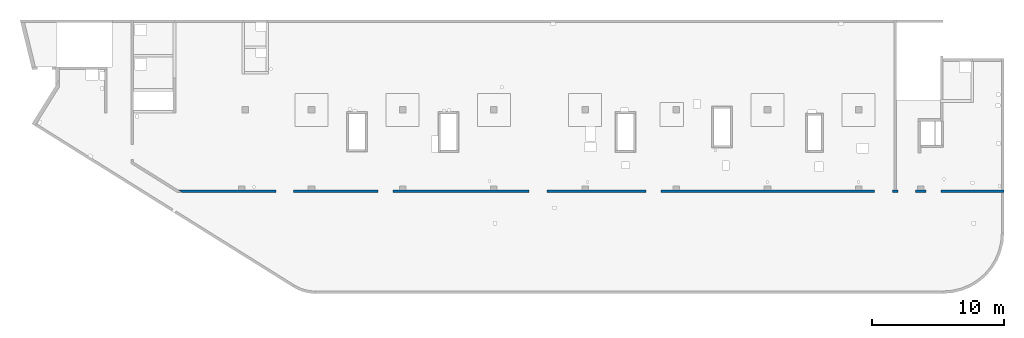
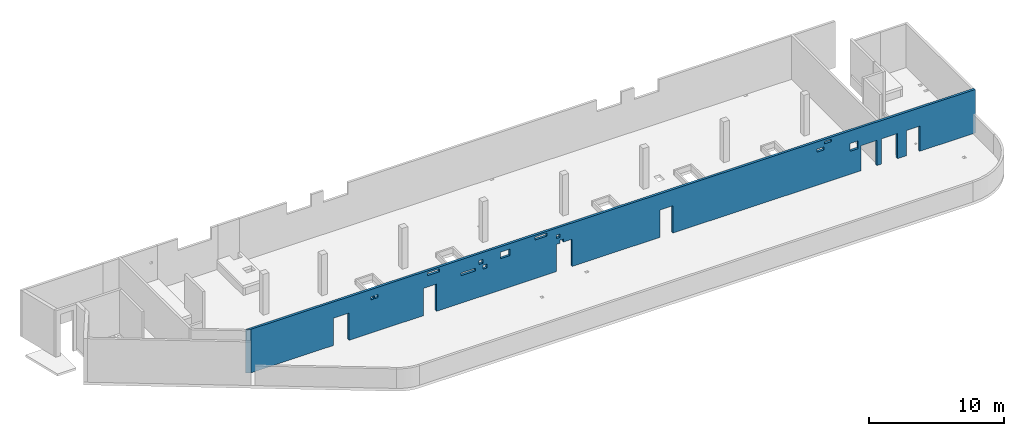
# One storey, part 5 of 6: 1 wall, 20 openings.
"""IFC4 building model written with IfcOpenShell, lengths in millimetres."""

from ifc_helpers import new_model, entity, si_unit, converted_unit, derived_unit, direction, frame, origin, place, context, subcontext, project, spatial, indexed_curve, outline, extrude, polygons, material, type_object, element, save


model = new_model("IFC4")

# Units and contexts
model_context = context("Model", 3, precision=0.01, world=origin(), true_north=direction((6.12303176911189e-17, 1.0)))
plan_context = context("Plan", 3, precision=0.01, world=origin(), true_north=direction((6.12303176911189e-17, 1.0)))
body_context = subcontext(model_context, "Body", "Model", "MODEL_VIEW")
ifc_project = project(units=[si_unit("LENGTHUNIT", "METRE", prefix="MILLI"), si_unit("AREAUNIT", "SQUARE_METRE"), si_unit("VOLUMEUNIT", "CUBIC_METRE"), converted_unit("PLANEANGLEUNIT", "DEGREE", entity("IfcRatioMeasure", 0.0174532925199433), si_unit("PLANEANGLEUNIT", "RADIAN"), dimensions=[0, 0, 0, 0, 0, 0, 0]), si_unit("MASSUNIT", "GRAM", prefix="KILO"), derived_unit("MASSDENSITYUNIT", [(si_unit("MASSUNIT", "GRAM", prefix="KILO"), 1), (si_unit("LENGTHUNIT", "METRE"), -3)]), derived_unit("MOMENTOFINERTIAUNIT", [(si_unit("LENGTHUNIT", "METRE"), 4)]), si_unit("TIMEUNIT", "SECOND"), si_unit("FREQUENCYUNIT", "HERTZ"), si_unit("THERMODYNAMICTEMPERATUREUNIT", "DEGREE_CELSIUS"), derived_unit("THERMALTRANSMITTANCEUNIT", [(si_unit("MASSUNIT", "GRAM", prefix="KILO"), 1), (si_unit("THERMODYNAMICTEMPERATUREUNIT", "KELVIN"), -1), (si_unit("TIMEUNIT", "SECOND"), -3)]), derived_unit("VOLUMETRICFLOWRATEUNIT", [(si_unit("LENGTHUNIT", "METRE"), 3), (si_unit("TIMEUNIT", "SECOND"), -1)]), derived_unit("MASSFLOWRATEUNIT", [(si_unit("MASSUNIT", "GRAM", prefix="KILO"), 1), (si_unit("TIMEUNIT", "SECOND"), -1)]), derived_unit("ROTATIONALFREQUENCYUNIT", [(si_unit("TIMEUNIT", "SECOND"), -1)]), si_unit("ELECTRICCURRENTUNIT", "AMPERE"), si_unit("ELECTRICVOLTAGEUNIT", "VOLT"), si_unit("POWERUNIT", "WATT"), si_unit("FORCEUNIT", "NEWTON", prefix="KILO"), si_unit("ILLUMINANCEUNIT", "LUX"), si_unit("LUMINOUSFLUXUNIT", "LUMEN"), si_unit("LUMINOUSINTENSITYUNIT", "CANDELA"), derived_unit("USERDEFINED", [(si_unit("MASSUNIT", "GRAM", prefix="KILO"), -1), (si_unit("LENGTHUNIT", "METRE"), -2), (si_unit("TIMEUNIT", "SECOND"), 3), (si_unit("LUMINOUSFLUXUNIT", "LUMEN"), 1)]), derived_unit("LINEARVELOCITYUNIT", [(si_unit("LENGTHUNIT", "METRE"), 1), (si_unit("TIMEUNIT", "SECOND"), -1)]), si_unit("PRESSUREUNIT", "PASCAL"), derived_unit("USERDEFINED", [(si_unit("LENGTHUNIT", "METRE"), -2), (si_unit("MASSUNIT", "GRAM", prefix="KILO"), 1), (si_unit("TIMEUNIT", "SECOND"), -2)]), derived_unit("LINEARFORCEUNIT", [(si_unit("MASSUNIT", "GRAM", prefix="KILO"), 1), (si_unit("LENGTHUNIT", "METRE"), 1), (si_unit("TIMEUNIT", "SECOND"), -2), (si_unit("LENGTHUNIT", "METRE"), -1)]), derived_unit("PLANARFORCEUNIT", [(si_unit("MASSUNIT", "GRAM", prefix="KILO"), 1), (si_unit("LENGTHUNIT", "METRE"), 1), (si_unit("TIMEUNIT", "SECOND"), -2), (si_unit("LENGTHUNIT", "METRE"), -2)])], contexts=[model_context, plan_context])

# Site, building, storey
site_placement = place(None, origin())
site = spatial("IfcSite", under=ifc_project, at=site_placement, CompositionType="ELEMENT")
building_placement = place(site_placement, origin())
building = spatial("IfcBuilding", under=site, at=building_placement, CompositionType="ELEMENT")
storey_placement = place(building_placement, frame((0.0, 0.0, 28200.0)))
storey = spatial("IfcBuildingStorey", under=building, at=storey_placement, CompositionType="ELEMENT", Elevation=28200.0)

# Wall, openings
ifc_material = material()
wall_type = type_object("IfcWallType", PredefinedType="STANDARD")
wall_placement = place(storey_placement, frame((11060.8176549435, 7549.99922635586, -150.0)))
wall = element("IfcWall", 1, at=wall_placement, inside=storey, type_object=wall_type, material=ifc_material, PredefinedType="NOTDEFINED", context=body_context, shape_type="Tessellation", body=[
    polygons([(62509.1817957401, -99.9999999999989, 3950.0), (320.073152365613, -100.0, 3950.0), (320.073152365616, -100.0, 0.0), (7409.18261361114, -99.9999999999989, 0.0), (7409.18261361114, -99.9999999999989, 2479.99999999805), (8759.18261361114, -99.9999999999989, 2479.99999999804), (8759.18261361114, -100.000000000001, 0.0), (15129.1826136111, -100.0, 0.0), (15129.1826136111, -100.0, 2479.99999999805), (16259.1826136111, -100.0, 2479.99999999804), (16259.1826136111, -100.0, 0.0), (26559.1826136111, -100.0, 0.0), (26559.1826136111, -100.0, 2479.99999999805), (26859.1826136111, -99.9999999999989, 2479.99999999805), (26859.1826136111, -100.000000000322, 2749.99999999994), (27159.1826136111, -100.000000000321, 2749.99999999994), (27159.1826136111, -100.0, 2479.99999999805), (27909.1826136111, -100.0, 2479.99999999804), (27909.1826136111, -100.0, 0.0), (35429.1826136111, -100.0, 0.0), (35429.1826136111, -100.0, 2479.99999999805), (36559.1826136111, -100.000000000001, 2479.99999999804), (36559.1826136111, -100.000000000001, 0.0), (52719.1826136111, -100.0, 0.0), (52719.1826136111, -100.0, 2279.99999999804), (54069.1826136111, -100.0, 2279.99999999804), (54069.1826136111, -100.0, 0.0), (54469.1826136111, -100.000000000001, 0.0), (54469.1826136111, -99.9999999999989, 2279.99999999804), (55819.1826136111, -100.000000000001, 2279.99999999804), (55819.1826136111, -100.000000000001, 0.0), (56619.1826136111, -100.0, 0.0), (56619.1826136111, -100.0, 2279.99999999804), (57749.1826136111, -100.0, 2279.99999999804), (57749.1826136111, -100.0, 0.0), (62309.1817957401, -100.0, 0.0), (62509.1817957401, -99.9999999999989, 0.0), (62509.1817957401, -100.0, 1770.0), (51759.1826136112, -100.000000000321, 2800.0), (52459.1826136112, -100.000000000321, 2800.0), (52459.1826136112, -100.000000000321, 2100.00000000002), (51759.1826136112, -100.000000000321, 2100.00000000002), (49569.1826136112, -100.000000000321, 3755.0), (50169.1826136112, -100.000000000322, 3755.0), (50169.1826136112, -100.000000000322, 3540.00000000001), (49569.1826136112, -100.000000000321, 3540.00000000001), (48924.1826136112, -100.000000000319, 3284.99999999999), (49524.1826136112, -100.000000000321, 3284.99999999999), (49524.1826136112, -100.000000000321, 3010.0), (48924.1826136112, -100.000000000319, 3010.0), (24729.1826136111, -100.000000000321, 3784.99999999994), (25729.1826136111, -100.000000000321, 3784.99999999994), (25729.1826136111, -100.000000000321, 3509.99999999995), (24729.1826136111, -100.000000000321, 3509.99999999995), (26559.1826136111, -100.000000000321, 3299.99999999994), (26859.1826136111, -100.000000000319, 3299.99999999994), (26859.1826136111, -100.000000000319, 2999.99999999995), (26559.1826136111, -100.000000000321, 2999.99999999995), (21774.1826136111, -100.000000000322, 3450.0), (22574.1826136111, -100.000000000322, 3450.0), (22574.1826136111, -100.000000000322, 2850.00000000001), (21774.1826136111, -100.000000000322, 2850.00000000001), (18359.1826136111, -100.000000000319, 2749.99999999998), (19609.1826136111, -100.000000000321, 2749.99999999998), (19609.1826136111, -100.000000000321, 2500.0), (18359.1826136111, -100.000000000319, 2500.0), (19904.1826136112, -100.000000000319, 3319.99999999999), (20254.1826136111, -100.000000000321, 3319.99999999999), (20254.1826136111, -100.000000000321, 2970.0), (19904.1826136112, -100.000000000319, 2970.0), (20254.1826136111, -100.000000000321, 2779.99999999998), (20604.1826136111, -100.000000000321, 2779.99999999998), (20604.1826136111, -100.000000000321, 2430.0), (20254.1826136111, -100.000000000321, 2430.0), (15504.1826136112, -100.000000000321, 3784.99999999997), (16504.1826136112, -100.000000000321, 3784.99999999997), (16504.1826136112, -100.000000000321, 3509.99999999998), (15504.1826136112, -100.000000000321, 3509.99999999998), (10624.1826136112, -100.000000000321, 3284.99999999995), (10899.1826136112, -100.000000000321, 3284.99999999995), (10899.1826136112, -100.000000000321, 3009.99999999997), (10624.1826136112, -100.000000000321, 3009.99999999997), (10974.1826136112, -100.000000000321, 3284.99999999995), (11249.1826136112, -100.000000000319, 3284.99999999995), (11249.1826136112, -100.000000000319, 3009.99999999997), (10974.1826136112, -100.000000000321, 3009.99999999997), (1.91187300746924e-12, 100.000000000001, 3950.0), (54169.1826136112, 100.0, 3950.0), (54369.1826136112, 100.0, 3950.0), (62309.1817957401, 100.0, 3950.0), (62509.1817957401, 100.0, 3950.0), (62509.1817957401, 100.0, 0.0), (62309.1817957401, 100.0, 0.0), (57749.1826136111, 100.000000000001, 0.0), (57749.1826136111, 100.000000000001, 2279.99999999804), (56619.1826136111, 100.0, 2279.99999999804), (56619.1826136111, 100.0, 0.0), (56459.1826136112, 100.0, 0.0), (55959.1826136112, 100.0, 0.0), (55819.1826136111, 100.0, 0.0), (55819.1826136111, 100.0, 2279.99999999804), (54469.1826136111, 100.0, 2279.99999999804), (54469.1826136111, 100.0, 0.0), (54369.1826136112, 100.0, 0.0), (54169.1826136112, 100.0, 0.0), (54069.1826136111, 100.0, 0.0), (54069.1826136111, 100.0, 2279.99999999804), (52719.1826136111, 100.0, 2279.99999999804), (52719.1826136111, 99.9999999999989, 0.0), (51759.1826136112, 100.0, 0.0), (51259.1826136112, 100.0, 0.0), (44859.1826136112, 100.000000000001, 0.0), (44359.1826136112, 100.0, 0.0), (37959.1826136112, 100.0, 0.0), (37459.1826136112, 100.0, 0.0), (36559.1826136111, 100.0, 0.0), (36559.1826136111, 100.0, 2479.99999999805), (35429.1826136111, 100.0, 2479.99999999805), (35429.1826136111, 100.0, 0.0), (31059.1826136112, 100.0, 0.0), (30559.1826136112, 100.0, 0.0), (27909.1826136111, 100.0, 0.0), (27909.1826136111, 100.0, 2479.99999999805), (27159.1826136111, 100.0, 2479.99999999805), (27159.1826136111, 100.0, 2749.99999999994), (26859.1826136111, 100.0, 2749.99999999994), (26859.1826136111, 100.0, 2479.99999999805), (26559.1826136111, 100.0, 2479.99999999805), (26559.1826136111, 100.0, 0.0), (24159.1826136112, 100.0, 0.0), (23659.1826136112, 100.0, 0.0), (17259.1826136112, 100.0, 0.0), (16759.1826136112, 100.0, 0.0), (16259.1826136111, 100.0, 0.0), (16259.1826136111, 100.0, 2479.99999999805), (15129.1826136111, 99.9999999999989, 2479.99999999805), (15129.1826136111, 99.9999999999989, 0.0), (10359.1826136112, 100.0, 0.0), (9859.18261361118, 100.0, 0.0), (8759.18261361114, 100.0, 0.0), (8759.18261361114, 100.0, 2479.99999999805), (7409.18261361114, 100.0, 2479.99999999805), (7409.18261361115, 100.0, 0.0), (5089.18186898228, 100.0, 0.0), (4589.18186898228, 100.0, 0.0), (-2.53861251127542e-13, 100.000000000001, 0.0), (52459.1826136112, 100.0, 2800.0), (51759.1826136112, 100.0, 2800.0), (51759.1826136112, 100.0, 2100.00000000002), (52459.1826136112, 100.0, 2100.00000000002), (50169.1826136112, 100.0, 3755.0), (49569.1826136112, 100.000000000001, 3755.0), (49569.1826136112, 100.000000000001, 3540.00000000001), (50169.1826136112, 100.0, 3540.00000000001), (49524.1826136112, 100.000000000001, 3284.99999999999), (48924.1826136112, 100.0, 3284.99999999999), (48924.1826136112, 100.0, 3010.0), (49524.1826136112, 100.000000000001, 3010.0), (25729.1826136111, 100.000000000001, 3784.99999999994), (24729.1826136111, 100.000000000001, 3784.99999999994), (24729.1826136111, 100.000000000001, 3509.99999999995), (25729.1826136111, 100.000000000001, 3509.99999999995), (26859.1826136111, 100.0, 3299.99999999994), (26559.1826136111, 100.0, 3299.99999999994), (26559.1826136111, 100.0, 2999.99999999995), (26859.1826136111, 100.0, 2999.99999999995), (22574.1826136111, 100.0, 3450.0), (21774.1826136111, 100.0, 3450.0), (21774.1826136111, 100.0, 2850.00000000001), (22574.1826136111, 100.0, 2850.00000000001), (19609.1826136111, 100.0, 2749.99999999998), (18359.1826136112, 100.000000000001, 2749.99999999998), (18359.1826136112, 100.000000000001, 2500.0), (19609.1826136111, 100.0, 2500.0), (20254.1826136111, 100.0, 3319.99999999999), (19904.1826136111, 100.0, 3319.99999999999), (19904.1826136111, 100.0, 2970.0), (20254.1826136111, 100.0, 2970.0), (20604.1826136111, 99.9999999999989, 2779.99999999998), (20254.1826136111, 100.000000000001, 2779.99999999998), (20254.1826136111, 100.000000000001, 2430.0), (20604.1826136111, 99.9999999999989, 2430.0), (16504.1826136112, 100.000000000001, 3784.99999999997), (15504.1826136112, 100.0, 3784.99999999997), (15504.1826136112, 100.0, 3509.99999999998), (16504.1826136112, 100.000000000001, 3509.99999999998), (10899.1826136112, 100.000000000001, 3284.99999999995), (10624.1826136112, 100.0, 3284.99999999995), (10624.1826136112, 100.0, 3009.99999999997), (10899.1826136112, 100.000000000001, 3009.99999999997), (11249.1826136112, 100.0, 3284.99999999995), (10974.1826136112, 100.000000000001, 3284.99999999995), (10974.1826136112, 100.000000000001, 3009.99999999997), (11249.1826136112, 100.0, 3009.99999999997)], [[[1, 2, 3, 4, 5, 6, 7, 8, 9, 10, 11, 12, 13, 14, 15, 16, 17, 18, 19, 20, 21, 22, 23, 24, 25, 26, 27, 28, 29, 30, 31, 32, 33, 34, 35, 36, 37, 38], [39, 40, 41, 42], [43, 44, 45, 46], [47, 48, 49, 50], [51, 52, 53, 54], [55, 56, 57, 58], [59, 60, 61, 62], [63, 64, 65, 66], [67, 68, 69, 70], [71, 72, 73, 74], [75, 76, 77, 78], [79, 80, 81, 82], [83, 84, 85, 86]], [[87, 88, 89, 90, 91, 92, 93, 94, 95, 96, 97, 98, 99, 100, 101, 102, 103, 104, 105, 106, 107, 108, 109, 110, 111, 112, 113, 114, 115, 116, 117, 118, 119, 120, 121, 122, 123, 124, 125, 126, 127, 128, 129, 130, 131, 132, 133, 134, 135, 136, 137, 138, 139, 140, 141, 142, 143, 144, 145, 146], [147, 148, 149, 150], [151, 152, 153, 154], [155, 156, 157, 158], [159, 160, 161, 162], [163, 164, 165, 166], [167, 168, 169, 170], [171, 172, 173, 174], [175, 176, 177, 178], [179, 180, 181, 182], [183, 184, 185, 186], [187, 188, 189, 190], [191, 192, 193, 194]], [[3, 146, 145, 144, 143, 4]], [[2, 1, 91, 90, 89, 88, 87]], [[3, 2, 87, 146]], [[37, 92, 91, 1, 38]], [[29, 102, 101, 30]], [[30, 101, 100, 31]], [[102, 29, 28, 103]], [[5, 142, 141, 6]], [[6, 141, 140, 7]], [[142, 5, 4, 143]], [[9, 136, 135, 10]], [[10, 135, 134, 11]], [[136, 9, 8, 137]], [[123, 18, 17, 124]], [[18, 123, 122, 19]], [[128, 13, 12, 129]], [[21, 118, 117, 22]], [[22, 117, 116, 23]], [[118, 21, 20, 119]], [[25, 108, 107, 26]], [[26, 107, 106, 27]], [[108, 25, 24, 109]], [[33, 96, 95, 34]], [[34, 95, 94, 35]], [[96, 33, 32, 97]], [[40, 39, 148, 147]], [[40, 147, 150, 41]], [[41, 150, 149, 42]], [[148, 39, 42, 149]], [[44, 43, 152, 151]], [[44, 151, 154, 45]], [[45, 154, 153, 46]], [[152, 43, 46, 153]], [[48, 47, 156, 155]], [[48, 155, 158, 49]], [[49, 158, 157, 50]], [[156, 47, 50, 157]], [[52, 51, 160, 159]], [[52, 159, 162, 53]], [[53, 162, 161, 54]], [[160, 51, 54, 161]], [[56, 55, 164, 163]], [[56, 163, 166, 57]], [[57, 166, 165, 58]], [[164, 55, 58, 165]], [[125, 16, 15, 126]], [[16, 125, 124, 17]], [[126, 15, 14, 127]], [[60, 59, 168, 167]], [[60, 167, 170, 61]], [[61, 170, 169, 62]], [[168, 59, 62, 169]], [[64, 63, 172, 171]], [[64, 171, 174, 65]], [[65, 174, 173, 66]], [[172, 63, 66, 173]], [[68, 67, 176, 175]], [[68, 175, 178, 69]], [[69, 178, 177, 70]], [[176, 67, 70, 177]], [[179, 72, 71, 180]], [[72, 179, 182, 73]], [[73, 182, 181, 74]], [[180, 71, 74, 181]], [[76, 75, 184, 183]], [[76, 183, 186, 77]], [[77, 186, 185, 78]], [[184, 75, 78, 185]], [[80, 79, 188, 187]], [[80, 187, 190, 81]], [[81, 190, 189, 82]], [[188, 79, 82, 189]], [[84, 83, 192, 191]], [[84, 191, 194, 85]], [[85, 194, 193, 86]], [[192, 83, 86, 193]], [[13, 128, 127, 14]], [[7, 140, 139, 138, 137, 8]], [[11, 134, 133, 132, 131, 130, 129, 12]], [[19, 122, 121, 120, 119, 20]], [[23, 116, 115, 114, 113, 112, 111, 110, 109, 24]], [[27, 106, 105, 104, 103, 28]], [[31, 100, 99, 98, 97, 32]], [[92, 37, 36, 35, 94, 93]]], closed=True),
])
opening_1_placement = place(wall_placement, frame((-11060.8176549435, -7549.99922635586, 150.0)))
element("IfcOpeningElement", 2, at=opening_1_placement, cuts=wall, PredefinedType="OPENING", context=body_context, shape_type="SweptSolid", body=[
    extrude(outline(indexed_curve([(-675.000000000003, -1239.99999999902), (674.999999999998, -1239.99999999902), (674.999999999998, 1239.99999999902), (-675.000000000003, 1239.99999999902), (-675.000000000003, -1239.99999999902)], self_intersect=False)), frame((19145.0002685546, 7349.99922635389, 1090.0), z_axis=(0.0, 1.0, 0.0), x_axis=(1.0, 0.0, 0.0)), (0.0, 0.0, 1.0), 400.000000001942),
])
opening_2_placement = place(wall_placement, frame((-11060.8176549435, -7549.99922635586, 150.0)))
element("IfcOpeningElement", 3, at=opening_2_placement, cuts=wall, PredefinedType="OPENING", context=body_context, shape_type="SweptSolid", body=[
    extrude(outline(indexed_curve([(-564.999999999997, -1239.99999999902), (565.000000000001, -1239.99999999902), (565.000000000001, 1239.99999999902), (-564.999999999997, 1239.99999999902), (-564.999999999997, -1239.99999999902)], self_intersect=False)), frame((26755.0002685546, 7349.99922635387, 1090.0), z_axis=(0.0, 1.0, 0.0), x_axis=(1.0, 0.0, 0.0)), (0.0, 0.0, 1.0), 400.000000001942),
])
opening_3_placement = place(wall_placement, frame((-11060.8176549435, -7549.99922635586, -4050.0)))
element("IfcOpeningElement", 4, at=opening_3_placement, cuts=wall, PredefinedType="OPENING", context=body_context, shape_type="SweptSolid", body=[
    extrude(outline(indexed_curve([(-675.000000000003, -1239.99999999902), (674.999999999998, -1239.99999999902), (674.999999999998, 1239.99999999902), (-675.000000000003, 1239.99999999902), (-675.000000000003, -1239.99999999902)], self_intersect=False)), frame((38295.0002685546, 7349.99922635383, 5290.0), z_axis=(0.0, 1.0, 0.0), x_axis=(1.0, 0.0, 0.0)), (0.0, 0.0, 1.0), 400.000000001943),
])
opening_4_placement = place(wall_placement, frame((-11060.8176549435, -7549.99922635586, -4050.0)))
element("IfcOpeningElement", 5, at=opening_4_placement, cuts=wall, PredefinedType="OPENING", context=body_context, shape_type="SweptSolid", body=[
    extrude(outline(indexed_curve([(-565.000000000001, -1239.99999999902), (565.000000000001, -1239.99999999902), (565.000000000001, 1239.99999999902), (-565.000000000001, 1239.99999999902), (-565.000000000001, -1239.99999999902)], self_intersect=False)), frame((47055.0002685546, 7349.9992263538, 5290.0), z_axis=(0.0, 1.0, 0.0), x_axis=(1.0, 0.0, 0.0)), (0.0, 0.0, 1.0), 400.000000001943),
])
opening_5_placement = place(wall_placement, frame((-11060.8176549435, -7549.99922635586, 150.0)))
element("IfcOpeningElement", 6, at=opening_5_placement, cuts=wall, PredefinedType="OPENING", context=body_context, shape_type="SweptSolid", body=[
    extrude(outline(indexed_curve([(-675.000000000003, -1139.99999999902), (674.999999999994, -1139.99999999902), (674.999999999994, 1139.99999999902), (-675.000000000003, 1139.99999999902), (-675.000000000003, -1139.99999999902)], self_intersect=False)), frame((64455.0002685546, 7349.99922635375, 990.0), z_axis=(0.0, 1.0, 0.0), x_axis=(1.0, 0.0, 0.0)), (0.0, 0.0, 1.0), 400.000000001943),
])
opening_6_placement = place(wall_placement, frame((-11060.8176549435, -7549.99922635586, 150.0)))
element("IfcOpeningElement", 7, at=opening_6_placement, cuts=wall, PredefinedType="OPENING", context=body_context, shape_type="SweptSolid", body=[
    extrude(outline(indexed_curve([(-675.000000000003, -1139.99999999902), (674.999999999994, -1139.99999999902), (674.999999999994, 1139.99999999902), (-675.000000000003, 1139.99999999902), (-675.000000000003, -1139.99999999902)], self_intersect=False)), frame((66205.0002685547, 7349.99922635374, 990.0), z_axis=(0.0, 1.0, 0.0), x_axis=(1.0, 0.0, 0.0)), (0.0, 0.0, 1.0), 400.000000001942),
])
opening_7_placement = place(wall_placement, frame((-11060.8176549435, -7549.99922635586, -4050.0)))
element("IfcOpeningElement", 8, at=opening_7_placement, cuts=wall, PredefinedType="OPENING", context=body_context, shape_type="SweptSolid", body=[
    extrude(outline(indexed_curve([(-565.000000000001, -1139.99999999902), (565.000000000001, -1139.99999999902), (565.000000000001, 1139.99999999902), (-565.000000000001, 1139.99999999902), (-565.000000000001, -1139.99999999902)], self_intersect=False)), frame((68245.0002685547, 7349.99922635374, 5190.0), z_axis=(0.0, 1.0, 0.0), x_axis=(1.0, 0.0, 0.0)), (0.0, 0.0, 1.0), 400.000000001942),
])
opening_8_placement = place(wall_placement, frame((-11060.8176549435, -7549.99922635586, 150.0)))
element("IfcOpeningElement", 9, at=opening_8_placement, cuts=wall, PredefinedType="OPENING", context=body_context, shape_type="SweptSolid", body=[
    extrude(outline(indexed_curve([(-150.000000000001, -134.999999999991), (150.000000000001, -134.999999999991), (150.000000000001, 134.999999999995), (-150.000000000001, 134.999999999995), (-150.000000000001, -134.999999999991)], self_intersect=False)), frame((38070.0002685546, 7449.99922635481, 2465.0), z_axis=(0.0, 1.0, 0.0), x_axis=(1.0, 0.0, 0.0)), (0.0, 0.0, 1.0), 200.000000000962),
])
opening_9_placement = place(wall_placement, frame((-11060.8176549435, -7549.99922635586, 150.0)))
element("IfcOpeningElement", 10, at=opening_9_placement, cuts=wall, PredefinedType="OPENING", context=body_context, shape_type="SweptSolid", body=[
    extrude(outline(indexed_curve([(-174.999999999999, -174.999999999991), (174.999999999999, -174.999999999991), (174.999999999999, 174.999999999995), (-174.999999999999, 174.999999999995), (-174.999999999999, -174.999999999991)], self_intersect=False)), frame((31140.0002685546, 7449.99922635483, 2995.0), z_axis=(0.0, 1.0, 0.0), x_axis=(1.0, 0.0, 0.0)), (0.0, 0.0, 1.0), 200.000000000962),
])
opening_10_placement = place(wall_placement, frame((-11060.8176549435, -7549.99922635586, 150.0)))
element("IfcOpeningElement", 11, at=opening_10_placement, cuts=wall, PredefinedType="OPENING", context=body_context, shape_type="SweptSolid", body=[
    extrude(outline(indexed_curve([(-175.000000000004, -174.999999999991), (174.999999999995, -174.999999999991), (174.999999999995, 174.999999999995), (-175.000000000004, 174.999999999995), (-175.000000000004, -174.999999999991)], self_intersect=False)), frame((31490.0002685547, 7449.99922635483, 2455.0), z_axis=(0.0, 1.0, 0.0), x_axis=(1.0, 0.0, 0.0)), (0.0, 0.0, 1.0), 200.000000000962),
])
opening_11_placement = place(wall_placement, frame((-11060.8176549435, -7549.99922635586, 150.0)))
element("IfcOpeningElement", 12, at=opening_11_placement, cuts=wall, PredefinedType="OPENING", context=body_context, shape_type="SweptSolid", body=[
    extrude(outline(indexed_curve([(-150.000000000001, -149.999999999992), (150.000000000001, -149.999999999992), (150.000000000001, 149.999999999992), (-150.000000000001, 149.999999999992), (-150.000000000001, -149.999999999992)], self_intersect=False)), frame((37770.0002685546, 7449.99922635481, 3000.0), z_axis=(0.0, 1.0, 0.0), x_axis=(1.0, 0.0, 0.0)), (0.0, 0.0, 1.0), 200.000000000962),
])
opening_12_placement = place(wall_placement, frame((-11060.8176549435, -7549.99922635586, 150.0)))
element("IfcOpeningElement", 13, at=opening_12_placement, cuts=wall, PredefinedType="OPENING", context=body_context, shape_type="SweptSolid", body=[
    extrude(outline(indexed_curve([(-349.999999999998, -349.999999999994), (349.999999999998, -349.999999999994), (349.999999999998, 349.99999999999), (-349.999999999998, 349.99999999999), (-349.999999999998, -349.999999999994)], self_intersect=False)), frame((63170.0002685547, 7449.99922635473, 2300.0), z_axis=(0.0, 1.0, 0.0), x_axis=(1.0, 0.0, 0.0)), (0.0, 0.0, 1.0), 200.000000000962),
])
opening_13_placement = place(wall_placement, frame((-11060.8176549435, -7549.99922635586, 150.0)))
element("IfcOpeningElement", 14, at=opening_13_placement, cuts=wall, PredefinedType="OPENING", context=body_context, shape_type="SweptSolid", body=[
    extrude(outline(indexed_curve([(-300.000000000001, -107.499999999993), (300.000000000001, -107.499999999993), (300.000000000001, 107.499999999993), (-300.000000000001, 107.499999999993), (-300.000000000001, -107.499999999993)], self_intersect=False)), frame((60930.0002685547, 7449.99922635474, 3497.5), z_axis=(0.0, 1.0, 0.0), x_axis=(1.0, 0.0, 0.0)), (0.0, 0.0, 1.0), 200.000000000962),
])
opening_14_placement = place(wall_placement, frame((-11060.8176549435, -7549.99922635586, 150.0)))
element("IfcOpeningElement", 15, at=opening_14_placement, cuts=wall, PredefinedType="OPENING", context=body_context, shape_type="SweptSolid", body=[
    extrude(outline(indexed_curve([(-300.000000000001, -137.49999999999), (300.000000000001, -137.49999999999), (300.000000000001, 137.499999999995), (-300.000000000001, 137.499999999995), (-300.000000000001, -137.49999999999)], self_intersect=False)), frame((60285.0002685547, 7449.99922635474, 2997.5), z_axis=(0.0, 1.0, 0.0), x_axis=(1.0, 0.0, 0.0)), (0.0, 0.0, 1.0), 200.000000000962),
])
opening_15_placement = place(wall_placement, frame((-11060.8176549435, -7549.99922635586, 150.0)))
element("IfcOpeningElement", 16, at=opening_15_placement, cuts=wall, PredefinedType="OPENING", context=body_context, shape_type="SweptSolid", body=[
    extrude(outline(indexed_curve([(-499.999999999999, -137.499999999995), (499.999999999999, -137.499999999995), (499.999999999999, 137.49999999999), (-499.999999999999, 137.49999999999), (-499.999999999999, -137.499999999995)], self_intersect=False)), frame((36290.0002685546, 7449.99922635482, 3497.49999999994), z_axis=(0.0, 1.0, 0.0), x_axis=(1.0, 0.0, 0.0)), (0.0, 0.0, 1.0), 200.000000000962),
])
opening_16_placement = place(wall_placement, frame((-11060.8176549435, -7549.99922635586, 150.0)))
element("IfcOpeningElement", 17, at=opening_16_placement, cuts=wall, PredefinedType="OPENING", context=body_context, shape_type="SweptSolid", body=[
    extrude(outline(indexed_curve([(-400.0, -299.999999999992), (400.0, -299.999999999992), (400.0, 299.999999999992), (-400.0, 299.999999999992), (-400.0, -299.999999999992)], self_intersect=False)), frame((33235.0002685546, 7449.99922635483, 3000.0), z_axis=(0.0, 1.0, 0.0), x_axis=(1.0, 0.0, 0.0)), (0.0, 0.0, 1.0), 200.000000000962),
])
opening_17_placement = place(wall_placement, frame((-11060.8176549435, -7549.99922635586, 150.0)))
element("IfcOpeningElement", 18, at=opening_17_placement, cuts=wall, PredefinedType="OPENING", context=body_context, shape_type="SweptSolid", body=[
    extrude(outline(indexed_curve([(-625.000000000005, -124.999999999998), (624.999999999996, -124.999999999998), (624.999999999996, 124.999999999989), (-625.000000000005, 124.999999999989), (-625.000000000005, -124.999999999998)], self_intersect=False)), frame((30045.0002685547, 7449.99922635484, 2475.0), z_axis=(0.0, 1.0, 0.0), x_axis=(1.0, 0.0, 0.0)), (0.0, 0.0, 1.0), 200.000000000962),
])
opening_18_placement = place(wall_placement, frame((-11060.8176549435, -7549.99922635586, 150.0)))
element("IfcOpeningElement", 19, at=opening_18_placement, cuts=wall, PredefinedType="OPENING", context=body_context, shape_type="SweptSolid", body=[
    extrude(outline(indexed_curve([(-499.999999999999, -137.49999999999), (499.999999999999, -137.49999999999), (499.999999999999, 137.499999999995), (-499.999999999999, 137.499999999995), (-499.999999999999, -137.49999999999)], self_intersect=False)), frame((27065.0002685547, 7449.99922635485, 3497.49999999997), z_axis=(0.0, 1.0, 0.0), x_axis=(1.0, 0.0, 0.0)), (0.0, 0.0, 1.0), 200.000000000962),
])
opening_19_placement = place(wall_placement, frame((-11060.8176549435, -7549.99922635586, 150.0)))
element("IfcOpeningElement", 20, at=opening_19_placement, cuts=wall, PredefinedType="OPENING", context=body_context, shape_type="SweptSolid", body=[
    extrude(outline(indexed_curve([(-137.499999999999, -137.49999999999), (137.499999999999, -137.49999999999), (137.499999999999, 137.499999999995), (-137.499999999999, 137.499999999995), (-137.499999999999, -137.49999999999)], self_intersect=False)), frame((21822.5002685547, 7449.99922635486, 2997.49999999996), z_axis=(0.0, 1.0, 0.0), x_axis=(1.0, 0.0, 0.0)), (0.0, 0.0, 1.0), 200.000000000962),
])
opening_20_placement = place(wall_placement, frame((-11060.8176549435, -7549.99922635586, 150.0)))
element("IfcOpeningElement", 21, at=opening_20_placement, cuts=wall, PredefinedType="OPENING", context=body_context, shape_type="SweptSolid", body=[
    extrude(outline(indexed_curve([(-137.499999999999, -137.49999999999), (137.499999999999, -137.49999999999), (137.499999999999, 137.499999999995), (-137.499999999999, 137.499999999995), (-137.499999999999, -137.49999999999)], self_intersect=False)), frame((22172.5002685547, 7449.99922635486, 2997.49999999996), z_axis=(0.0, 1.0, 0.0), x_axis=(1.0, 0.0, 0.0)), (0.0, 0.0, 1.0), 200.000000000962),
])

save(model, "model.ifc")
